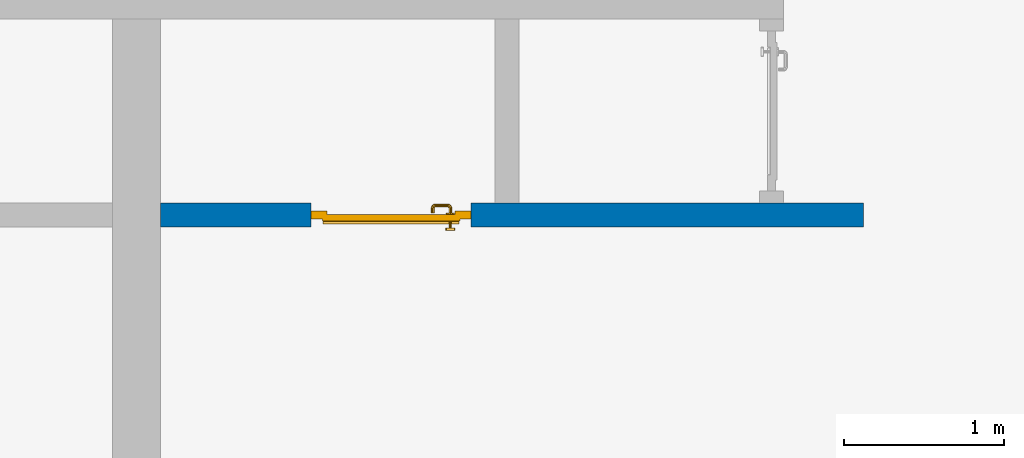
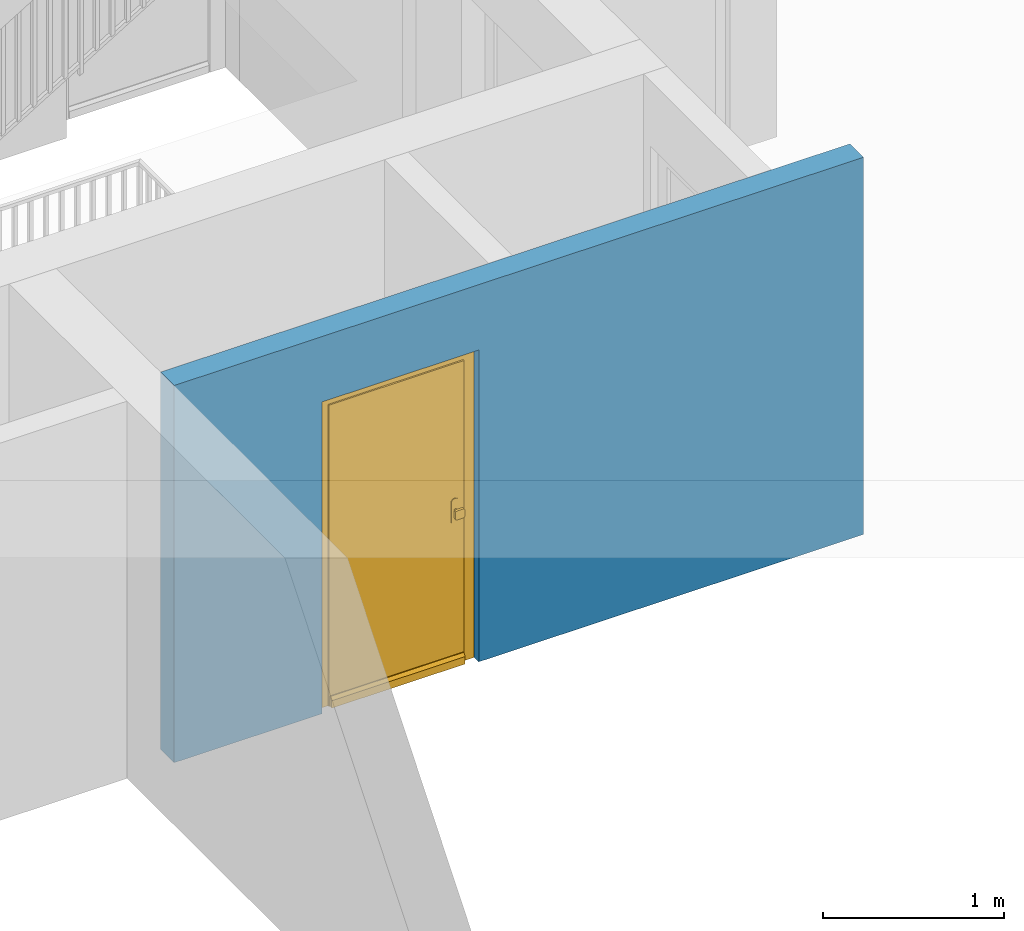
# One storey, part 3 of 48: 1 door, 1 wall, 1 opening.
"""IFC4 building model written with IfcOpenShell, lengths in metres."""

import ifcopenshell
import ifcopenshell.guid

model = None  # the IFC model being written
_history = None  # IfcOwnerHistory: only IFC2X3 demands one
_inside = {}  # id of a spatial element -> (the spatial element, [elements in it])
_under = {}  # id of a project, library or spatial element -> (it, [spatial elements below it])
_declared = {}  # id of a project -> (the project, [libraries it declares])
_typed = {}  # id of a type object -> (the type object, [elements of that type])
_made_of = {}  # id of a material, layer set ... -> (it, [elements and type objects made of it])


def new_model(schema):
    """Start an empty IFC model of exactly this schema.

    Asked for "IFC4X3", IfcOpenShell would pick the latest addendum, in which some entities
    have other attributes; the version numbers below select the first issue.
    IFC2X3 requires an IfcOwnerHistory on every rooted entity: one is made here for all.
    """
    global model, _history
    if schema == "IFC4X3":
        model = ifcopenshell.file(schema_version=(4, 3, 0, 0))
    else:
        model = ifcopenshell.file(schema=schema)
    _inside.clear()
    _under.clear()
    _declared.clear()
    _typed.clear()
    _made_of.clear()
    _history = None
    if model.schema == "IFC2X3":
        org = make("IfcOrganization", Name="unknown")
        user = make(
            "IfcPersonAndOrganization",
            ThePerson=make("IfcPerson", FamilyName="unknown"),
            TheOrganization=org,
        )
        app = make(
            "IfcApplication",
            ApplicationDeveloper=org,
            Version="unknown",
            ApplicationFullName="unknown",
            ApplicationIdentifier="unknown",
        )
        _history = make(
            "IfcOwnerHistory",
            OwningUser=user,
            OwningApplication=app,
            ChangeAction="ADDED",
            CreationDate=0,
        )
    return model


def make(cls, **values):
    """One entity of the class cls with the attributes given. An attribute that is None is left unset."""
    return model.create_entity(
        cls, **{name: value for name, value in values.items() if value is not None}
    )


def entity(cls, *values):
    """Any entity or typed value of the class cls, its attributes in the order of the schema. None: left unset."""
    e = model.create_entity(cls)
    for i, value in enumerate(values):
        if value is not None:
            e[i] = value
    return e


def rooted(cls, **values):
    """An entity with a GlobalId (a new one), such as an element, a storey or a relation."""
    return make(cls, GlobalId=ifcopenshell.guid.new(), OwnerHistory=_history, **values)


def si_unit(unit_type, name, prefix=None):
    """IfcSIUnit, for example si_unit("LENGTHUNIT", "METRE", prefix="MILLI")."""
    return make("IfcSIUnit", UnitType=unit_type, Prefix=prefix, Name=name)


def converted_unit(unit_type, name, factor, base, dimensions=None, offset=None):
    """IfcConversionBasedUnit, such as the inch: factor (a typed value) times the base unit."""
    return make(
        "IfcConversionBasedUnit"
        if offset is None
        else "IfcConversionBasedUnitWithOffset",
        ConversionOffset=offset,
        Dimensions=None
        if dimensions is None
        else entity("IfcDimensionalExponents", *dimensions),
        UnitType=unit_type,
        Name=name,
        ConversionFactor=make(
            "IfcMeasureWithUnit", ValueComponent=factor, UnitComponent=base
        ),
    )


def derived_unit(unit_type, elements):
    """IfcDerivedUnit: a product of units, each with its exponent."""
    return make(
        "IfcDerivedUnit",
        Elements=[
            make("IfcDerivedUnitElement", Unit=unit, Exponent=power)
            for unit, power in elements
        ],
        UnitType=unit_type,
    )


def assignment(units):
    """IfcUnitAssignment: the units of a project."""
    return None if units is None else make("IfcUnitAssignment", Units=units)


def point(xyz):
    """IfcCartesianPoint."""
    return None if xyz is None else make("IfcCartesianPoint", Coordinates=xyz)


def direction(xyz):
    """IfcDirection."""
    return None if xyz is None else make("IfcDirection", DirectionRatios=xyz)


def frame(location, z_axis=None, x_axis=None):
    """IfcAxis2Placement3D, a coordinate frame: its origin and axes. An axis left out is left unset."""
    return make(
        "IfcAxis2Placement3D",
        Location=point(location),
        Axis=direction(z_axis),
        RefDirection=direction(x_axis),
    )


def origin_with_axes():
    """The frame at (0, 0, 0) with the z axis (0, 0, 1) and the x axis (1, 0, 0) written out."""
    return frame((0.0, 0.0, 0.0), z_axis=(0.0, 0.0, 1.0), x_axis=(1.0, 0.0, 0.0))


def place(relative_to, where):
    """IfcLocalPlacement: puts the frame where relative to a parent placement (None: the world)."""
    return make(
        "IfcLocalPlacement", PlacementRelTo=relative_to, RelativePlacement=where
    )


def context(
    kind, dimensions, precision=None, world=None, true_north=None, identifier=None
):
    """IfcGeometricRepresentationContext, for example the 3D "Model" context."""
    return make(
        "IfcGeometricRepresentationContext",
        ContextIdentifier=identifier,
        ContextType=kind,
        CoordinateSpaceDimension=dimensions,
        Precision=precision,
        WorldCoordinateSystem=world,
        TrueNorth=true_north,
    )


def subcontext(parent, identifier, kind, view, scale=None):
    """IfcGeometricRepresentationSubContext, for example "Body" below "Model"."""
    return make(
        "IfcGeometricRepresentationSubContext",
        ContextIdentifier=identifier,
        ContextType=kind,
        ParentContext=parent,
        TargetScale=scale,
        TargetView=view,
    )


def project(units=None, contexts=None):
    """IfcProject with its units and contexts."""
    return rooted(
        "IfcProject",
        Name="project",
        RepresentationContexts=contexts,
        UnitsInContext=assignment(units),
    )


def spatial(cls, under=None, at=None, **own):
    """A site, building, storey or space (cls), placed at a placement, below another one or the project."""
    s = rooted(cls, ObjectPlacement=at, **own)
    if under is not None:
        _under.setdefault(under.id(), (under, []))[1].append(s)
    return s


def point_list(points):
    """IfcCartesianPointList2D or 3D."""
    cls = (
        "IfcCartesianPointList2D" if len(points[0]) == 2 else "IfcCartesianPointList3D"
    )
    return make(cls, CoordList=points)


def polygons(points, faces, closed=None, point_numbers=None):
    """IfcPolygonalFaceSet: a face is its outer loop, then its inner loops; points numbered from 1."""
    made = []
    for loops in faces:
        if len(loops) == 1:
            made.append(make("IfcIndexedPolygonalFace", CoordIndex=loops[0]))
        else:
            made.append(
                make(
                    "IfcIndexedPolygonalFaceWithVoids",
                    CoordIndex=loops[0],
                    InnerCoordIndices=loops[1:],
                )
            )
    return make(
        "IfcPolygonalFaceSet",
        Coordinates=point_list(points),
        Closed=closed,
        Faces=made,
        PnIndex=point_numbers,
    )


def shape(context_of_items, identifier, shape_type, items):
    """IfcShapeRepresentation: the items that make up one representation, for example the "Body"."""
    return make(
        "IfcShapeRepresentation",
        ContextOfItems=context_of_items,
        RepresentationIdentifier=identifier,
        RepresentationType=shape_type,
        Items=items,
    )


def source(mapping_origin, context_of_items, identifier, shape_type, items):
    """IfcRepresentationMap: a shape defined once, which mapped items show again and again."""
    return make(
        "IfcRepresentationMap",
        MappingOrigin=mapping_origin,
        MappedRepresentation=shape(context_of_items, identifier, shape_type, items),
    )


def transform(
    local_origin,
    x_axis=None,
    y_axis=None,
    z_axis=None,
    scale=None,
    scale2=None,
    scale3=None,
    uniform=True,
):
    """IfcCartesianTransformationOperator3D, or its non-uniform kind. x_axis, y_axis, z_axis: its Axis1, 2, 3."""
    if uniform:
        return make(
            "IfcCartesianTransformationOperator3D",
            Axis1=direction(x_axis),
            Axis2=direction(y_axis),
            LocalOrigin=point(local_origin),
            Scale=scale,
            Axis3=direction(z_axis),
        )
    return make(
        "IfcCartesianTransformationOperator3DnonUniform",
        Axis1=direction(x_axis),
        Axis2=direction(y_axis),
        LocalOrigin=point(local_origin),
        Scale=scale,
        Axis3=direction(z_axis),
        Scale2=scale2,
        Scale3=scale3,
    )


def mapped(mapping_source, mapping_target):
    """IfcMappedItem: shows the shape of a source again, moved by a transform."""
    return make(
        "IfcMappedItem", MappingSource=mapping_source, MappingTarget=mapping_target
    )


def material(Name=None, Category=None):
    """IfcMaterial."""
    return make("IfcMaterial", Name=Name, Category=Category)


def made_of(thing, what):
    """Note that an element or type object is made of a material, layer set ...; save() writes the relation."""
    if what is not None:
        _made_of.setdefault(what.id(), (what, []))[1].append(thing)
    return thing


def type_object(cls, material=None, **own):
    """A type object (cls), such as IfcWallType, which elements share."""
    return made_of(rooted(cls, **own), material)


def element(
    cls,
    number,
    at=None,
    inside=None,
    cuts=None,
    type_object=None,
    material=None,
    context=None,
    identifier="Body",
    shape_type=None,
    held_by="IfcProductDefinitionShape",
    body=None,
    shapes=None,
    **own,
):
    """One element of the class cls, such as IfcWall. Its Tag is "e" and its number.

    at: its placement. inside: the storey or other place that contains it. cuts: it is an
    opening in that element (IfcRelVoidsElement). A single representation is given by context,
    identifier, shape_type and body (its items); several are given by shapes. held_by: the class
    of the entity that holds the representations. save() writes the other relations.
    """
    e = rooted(cls, Tag="e%d" % number, ObjectPlacement=at, **own)
    if body is not None:
        shapes = [shape(context, identifier, shape_type, body)]
    if shapes is not None:
        e.Representation = make(held_by, Representations=shapes)
    if inside is not None:
        _inside.setdefault(inside.id(), (inside, []))[1].append(e)
    if cuts is not None:
        rooted(
            "IfcRelVoidsElement", RelatingBuildingElement=cuts, RelatedOpeningElement=e
        )
    if type_object is not None:
        _typed.setdefault(type_object.id(), (type_object, []))[1].append(e)
    return made_of(e, material)


def fill(opening, filler):
    """IfcRelFillsElement: the door or window that sits in an opening."""
    return rooted(
        "IfcRelFillsElement",
        RelatingOpeningElement=opening,
        RelatedBuildingElement=filler,
    )


def aggregate(whole, parts):
    """IfcRelAggregates: a whole, such as a stair, and the parts it consists of."""
    return rooted("IfcRelAggregates", RelatingObject=whole, RelatedObjects=parts)


def save(model, path):
    """Write the relations noted so far, then the file.

    IfcRelAggregates (storeys below a building ...), IfcRelContainedInSpatialStructure (elements
    in a storey), IfcRelDefinesByType, IfcRelAssociatesMaterial and IfcRelDeclares: one each for
    every whole, place, type object, material and project.
    """
    for whole, parts in _under.values():
        aggregate(whole, parts)
    for where, things in _inside.values():
        rooted(
            "IfcRelContainedInSpatialStructure",
            RelatedElements=things,
            RelatingStructure=where,
        )
    for kind, things in _typed.values():
        rooted("IfcRelDefinesByType", RelatedObjects=things, RelatingType=kind)
    for what, things in _made_of.values():
        rooted("IfcRelAssociatesMaterial", RelatedObjects=things, RelatingMaterial=what)
    for by, libraries in _declared.values():
        rooted("IfcRelDeclares", RelatingContext=by, RelatedDefinitions=libraries)
    model.write(path)


model = new_model("IFC4")

# Units and contexts
model_context = context("Model", 3, precision=1e-05, world=origin_with_axes(), true_north=direction((0.0, 1.0)))
body_context = subcontext(model_context, "Body", "Model", "MODEL_VIEW")
ifc_project = project(units=[si_unit("LENGTHUNIT", "METRE"), si_unit("AREAUNIT", "SQUARE_METRE"), si_unit("VOLUMEUNIT", "CUBIC_METRE"), converted_unit("PLANEANGLEUNIT", "DEGREE", entity("IfcPlaneAngleMeasure", 0.0174532925199), si_unit("PLANEANGLEUNIT", "RADIAN"), dimensions=[0, 0, 0, 0, 0, 0, 0]), converted_unit("TIMEUNIT", "Year", entity("IfcTimeMeasure", 31556926.0), si_unit("TIMEUNIT", "SECOND"), dimensions=[0, 0, 1, 0, 0, 0, 0]), si_unit("MASSUNIT", "GRAM", prefix="KILO"), si_unit("THERMODYNAMICTEMPERATUREUNIT", "DEGREE_CELSIUS"), si_unit("LUMINOUSINTENSITYUNIT", "LUMEN"), si_unit("ENERGYUNIT", "JOULE", prefix="MEGA"), derived_unit("THERMALCONDUCTANCEUNIT", [(si_unit("POWERUNIT", "WATT"), 1), (si_unit("LENGTHUNIT", "METRE"), -1), (si_unit("THERMODYNAMICTEMPERATUREUNIT", "KELVIN"), -1)]), derived_unit("SPECIFICHEATCAPACITYUNIT", [(si_unit("ENERGYUNIT", "JOULE"), 1), (si_unit("MASSUNIT", "GRAM", prefix="KILO"), -1), (si_unit("THERMODYNAMICTEMPERATUREUNIT", "KELVIN"), -1)]), derived_unit("MASSDENSITYUNIT", [(si_unit("MASSUNIT", "GRAM", prefix="KILO"), 1), (si_unit("VOLUMEUNIT", "CUBIC_METRE"), -1)])], contexts=[model_context])

# Site, building, storey
site_placement = place(None, origin_with_axes())
site = spatial("IfcSite", under=ifc_project, at=site_placement, CompositionType="ELEMENT")
building_placement = place(site_placement, origin_with_axes())
building = spatial("IfcBuilding", under=site, at=building_placement, CompositionType="ELEMENT")
storey_placement = place(building_placement, frame((0.0, 0.0, 3.4), z_axis=(0.0, 0.0, 1.0), x_axis=(1.0, 0.0, 0.0)))
storey = spatial("IfcBuildingStorey", under=building, at=storey_placement, Name="1. Geschoss", CompositionType="ELEMENT", Elevation=3.4)

# Wall, opening, door
ifc_material = material()
wall_type = type_object("IfcWallType", Name="150", PredefinedType="NOTDEFINED")
wall_placement = place(storey_placement, frame((-1.2021993804, -4.12881223104, 0.0), z_axis=(0.0, 0.0, 1.0), x_axis=(1.0, 0.0, 0.0)))
wall = element("IfcWall", 1, at=wall_placement, inside=storey, type_object=wall_type, material=ifc_material, Name="Wand-002", PredefinedType="NOTDEFINED", context=body_context, shape_type="Tessellation", body=[
    polygons([(1.09, 0.15, 2.1), (1.09, 0.15, 0.0), (0.15, 0.15, 0.0), (0.15, 0.15, 2.54), (4.54, 0.15, 2.54), (4.54, 0.15, 0.0), (2.09, 0.15, 0.0), (2.09, 0.15, 2.1), (1.09, 0.05, 0.0), (1.09, 0.0, 2.1), (1.09, 0.0, 0.0), (0.15, 0.0, 0.0), (0.15, 0.0, 2.54), (4.54, 0.0, 2.54), (4.54, 0.0, 0.0), (2.09, 0.05, 0.0), (2.09, 0.0, 0.0), (2.09, 0.0, 2.1)], [[[1, 2, 3, 4, 5, 6, 7, 8]], [[9, 2, 1, 10, 11]], [[2, 9, 11, 12, 3]], [[4, 3, 12, 13]], [[5, 4, 13, 14]], [[14, 15, 6, 5]], [[16, 7, 6, 15, 17]], [[8, 7, 16, 17, 18]], [[1, 8, 18, 10]], [[12, 11, 10, 18, 17, 15, 14, 13]]], closed=True),
])
opening_placement = place(wall_placement, frame((1.59, 0.0, 0.0), z_axis=(0.0, 0.0, 1.0), x_axis=(1.0, 0.0, 0.0)))
opening = element("IfcOpeningElement", 2, at=opening_placement, cuts=wall, context=body_context, identifier="Reference", shape_type="Tessellation", body=[
    polygons([(0.5, 0.05, 0.0), (0.5, 0.05, 2.1), (0.5, -0.001, 2.1), (0.5, -0.001, 0.0), (0.5, 0.151, 0.0), (0.5, 0.151, 2.1), (-0.5, 0.05, 2.1), (-0.5, -0.001, 2.1), (-0.5, 0.151, 2.1), (-0.5, -0.001, 0.0), (-0.5, 0.05, 0.0), (-0.5, 0.151, 0.0)], [[[1, 2, 3, 4]], [[2, 1, 5, 6]], [[7, 8, 3, 2, 6, 9]], [[8, 10, 4, 3]], [[1, 4, 10, 11, 12, 5]], [[6, 5, 12, 9]], [[7, 11, 10, 8]], [[11, 7, 9, 12]]], closed=True),
])
door_type = type_object("IfcDoorType", Name="Eingang 01 1-Fl 26", OperationType="SINGLE_SWING_RIGHT", PredefinedType="DOOR")
shared_shape = source(origin_with_axes(), body_context, "Body", "Tessellation", [
    polygons([(0.5, -0.05, 0.0), (0.5, -0.03, 0.0), (0.5, -0.03, 2.1), (0.5, -0.05, 2.1), (0.4, -0.05, 0.0), (0.4, -0.03, 0.0), (0.4, -0.03, 2.0), (0.1301, -0.03, 2.0), (0.0001, -0.03, 2.0), (-0.4, -0.03, 2.0), (-0.4, -0.03, 0.0), (-0.5, -0.03, 0.0), (-0.5, -0.03, 2.1), (-0.5, -0.05, 2.1), (-0.5, -0.05, 0.0), (-0.4, -0.05, 0.0), (-0.4, -0.05, 2.0), (0.0001, -0.05, 2.0), (0.1301, -0.05, 2.0), (0.4, -0.05, 2.0)], [[[1, 2, 3, 4]], [[5, 6, 2, 1]], [[2, 6, 7, 8, 9, 10, 11, 12, 13, 3]], [[4, 3, 13, 14]], [[1, 4, 14, 15, 16, 17, 18, 19, 20, 5]], [[20, 7, 6, 5]], [[19, 8, 7, 20]], [[18, 9, 8, 19]], [[17, 10, 9, 18]], [[16, 11, 10, 17]], [[15, 12, 11, 16]], [[14, 13, 12, 15]]], closed=True),
    polygons([(0.5, -0.03, 0.0), (0.5, 0.0, 0.0), (0.5, 0.0, 2.1), (0.5, -0.03, 2.1), (0.43, -0.03, 0.0), (0.43, 0.0, 0.0), (0.43, 0.0, 2.03), (0.1001, 0.0, 2.03), (0.0301, 0.0, 2.03), (-0.43, 0.0, 2.03), (-0.43, 0.0, 0.0), (-0.5, 0.0, 0.0), (-0.5, 0.0, 2.1), (-0.5, -0.03, 2.1), (-0.5, -0.03, 0.0), (-0.43, -0.03, 0.0), (-0.43, -0.03, 2.03), (0.0301, -0.03, 2.03), (0.1001, -0.03, 2.03), (0.43, -0.03, 2.03)], [[[1, 2, 3, 4]], [[5, 6, 2, 1]], [[2, 6, 7, 8, 9, 10, 11, 12, 13, 3]], [[4, 3, 13, 14]], [[1, 4, 14, 15, 16, 17, 18, 19, 20, 5]], [[20, 7, 6, 5]], [[19, 8, 7, 20]], [[18, 9, 8, 19]], [[17, 10, 9, 18]], [[16, 11, 10, 17]], [[15, 12, 11, 16]], [[14, 13, 12, 15]]], closed=True),
    polygons([(0.43, 0.01, 0.0), (-0.43, 0.01, 0.0), (-0.43, 0.01, 2.03), (0.43, 0.01, 2.03), (0.43, -0.03, 0.0), (-0.43, -0.03, 0.0), (-0.43, -0.03, 2.03), (0.43, -0.03, 2.03)], [[[1, 2, 3, 4]], [[2, 1, 5, 6]], [[3, 2, 6, 7]], [[4, 3, 7, 8]], [[1, 4, 8, 5]], [[6, 5, 8, 7]]], closed=True),
    polygons([(0.425, 0.03, 0.0), (-0.425, 0.03, 0.0), (-0.425, 0.03, 0.05), (0.425, 0.03, 0.05), (0.425, 0.01, 0.0), (-0.425, 0.01, 0.0), (-0.425, 0.01, 0.07), (-0.425, 0.015, 0.07), (0.425, 0.015, 0.07), (0.425, 0.01, 0.07)], [[[1, 2, 3, 4]], [[5, 6, 2, 1]], [[2, 6, 7, 8, 3]], [[4, 3, 8, 9]], [[1, 4, 9, 10, 5]], [[10, 7, 6, 5]], [[9, 8, 7, 10]]], closed=True),
    polygons([(-0.3835, -0.04, 1.0733826859), (-0.37, -0.04, 1.077), (-0.37, -0.0399, 1.077), (-0.3835, -0.0399, 1.0733826859), (-0.393382685902, -0.04, 1.0635), (-0.397, -0.04, 1.05), (-0.393382685902, -0.04, 1.0365), (-0.3835, -0.04, 1.0266173141), (-0.37, -0.04, 1.023), (-0.3565, -0.04, 1.0266173141), (-0.346617314098, -0.04, 1.0365), (-0.343, -0.04, 1.05), (-0.346617314098, -0.04, 1.0635), (-0.3565, -0.04, 1.0733826859), (-0.3565, -0.0399, 1.0733826859), (-0.37, -0.0301, 1.077), (-0.3835, -0.0301, 1.0733826859), (-0.393382685902, -0.0399, 1.0635), (-0.397, -0.0399, 1.05), (-0.393382685902, -0.0399, 1.0365), (-0.3835, -0.0399, 1.0266173141), (-0.37, -0.0399, 1.023), (-0.3565, -0.0399, 1.0266173141), (-0.346617314098, -0.0399, 1.0365), (-0.343, -0.0399, 1.05), (-0.346617314098, -0.0399, 1.0635), (-0.3565, -0.0301, 1.0733826859), (-0.37, -0.03, 1.077), (-0.3835, -0.03, 1.0733826859), (-0.393382685902, -0.0301, 1.0635), (-0.397, -0.0301, 1.05), (-0.393382685902, -0.0301, 1.0365), (-0.3835, -0.0301, 1.0266173141), (-0.37, -0.0301, 1.023), (-0.3565, -0.0301, 1.0266173141), (-0.346617314098, -0.0301, 1.0365), (-0.343, -0.0301, 1.05), (-0.346617314098, -0.0301, 1.0635), (-0.3565, -0.03, 1.0733826859), (-0.346617314098, -0.03, 1.0635), (-0.343, -0.03, 1.05), (-0.346617314098, -0.03, 1.0365), (-0.3565, -0.03, 1.0266173141), (-0.37, -0.03, 1.023), (-0.3835, -0.03, 1.0266173141), (-0.393382685902, -0.03, 1.0365), (-0.397, -0.03, 1.05), (-0.393382685902, -0.03, 1.0635)], [[[1, 2, 3, 4]], [[2, 1, 5, 6, 7, 8, 9, 10, 11, 12, 13, 14]], [[2, 14, 15, 3]], [[4, 3, 16, 17]], [[5, 1, 4, 18]], [[6, 5, 18, 19]], [[7, 6, 19, 20]], [[8, 7, 20, 21]], [[9, 8, 21, 22]], [[10, 9, 22, 23]], [[11, 10, 23, 24]], [[12, 11, 24, 25]], [[13, 12, 25, 26]], [[14, 13, 26, 15]], [[3, 15, 27, 16]], [[17, 16, 28, 29]], [[18, 4, 17, 30]], [[19, 18, 30, 31]], [[20, 19, 31, 32]], [[21, 20, 32, 33]], [[22, 21, 33, 34]], [[23, 22, 34, 35]], [[24, 23, 35, 36]], [[25, 24, 36, 37]], [[26, 25, 37, 38]], [[15, 26, 38, 27]], [[16, 27, 39, 28]], [[28, 39, 40, 41, 42, 43, 44, 45, 46, 47, 48, 29]], [[30, 17, 29, 48]], [[31, 30, 48, 47]], [[32, 31, 47, 46]], [[33, 32, 46, 45]], [[34, 33, 45, 44]], [[35, 34, 44, 43]], [[36, 35, 43, 42]], [[37, 36, 42, 41]], [[38, 37, 41, 40]], [[27, 38, 40, 39]]], closed=True),
    polygons([(-0.362532169224, -0.04, 0.959692280177), (-0.365, -0.04, 0.9544), (-0.365, -0.04, 0.952886751346), (-0.346703916638, -0.04, 0.96345), (-0.35655, -0.04, 0.973296083362), (-0.363279754556, -0.04, 0.961639806549), (-0.362532169224, -0.039, 0.959692280177), (-0.365, -0.039, 0.9544), (-0.365, -0.039, 0.952886751346), (-0.365, -0.039, 0.95), (-0.365, -0.039, 0.947113248654), (-0.365, -0.039, 0.941339745962), (-0.365, -0.039, 0.9375), (-0.365, -0.04, 0.9375), (-0.365, -0.04, 0.941339745962), (-0.365, -0.04, 0.947113248654), (-0.365, -0.04, 0.95), (-0.3431, -0.04, 0.95), (-0.346617314098, -0.04, 0.9635), (-0.3565, -0.04, 0.973382685902), (-0.364624817685, -0.04, 0.965143815798), (-0.37, -0.04, 0.9769), (-0.37, -0.04, 0.967425445323), (-0.364624817685, -0.039, 0.965143815798), (-0.363279754556, -0.039, 0.961639806549), (-0.35705, -0.039, 0.972430057958), (-0.347569942042, -0.039, 0.96295), (-0.3441, -0.039, 0.95), (-0.347569942042, -0.039, 0.93705), (-0.35705, -0.039, 0.927569942042), (-0.37, -0.039, 0.9241), (-0.37, -0.039, 0.9325), (-0.366464466094, -0.039, 0.933964466094), (-0.366464466094, -0.04, 0.933964466094), (-0.35655, -0.04, 0.926703916638), (-0.37, -0.04, 0.9325), (-0.37, -0.04, 0.9231), (-0.346703916638, -0.04, 0.93655), (-0.343, -0.04, 0.95), (-0.346617314098, -0.0399, 0.9635), (-0.3565, -0.0399, 0.973382685902), (-0.37, -0.04, 0.977), (-0.375375182315, -0.04, 0.965143815798), (-0.38345, -0.04, 0.973296083362), (-0.376720245444, -0.04, 0.961639806549), (-0.37, -0.039, 0.967425445323), (-0.37, -0.039, 0.9759), (-0.357, -0.039, 0.972516660498), (-0.347483339502, -0.039, 0.963), (-0.344, -0.039, 0.95), (-0.347483339502, -0.039, 0.937), (-0.357, -0.039, 0.927483339502), (-0.38295, -0.039, 0.927569942042), (-0.375, -0.039, 0.941339745962), (-0.375, -0.039, 0.9375), (-0.373535533906, -0.039, 0.933964466094), (-0.37, -0.039, 0.924), (-0.373535533906, -0.04, 0.933964466094), (-0.375, -0.04, 0.9375), (-0.375, -0.04, 0.941339745962), (-0.38345, -0.04, 0.926703916638), (-0.37, -0.04, 0.923), (-0.3565, -0.04, 0.926617314098), (-0.346617314098, -0.04, 0.9365), (-0.343, -0.0399, 0.95), (-0.346617314098, -0.0301, 0.9635), (-0.3565, -0.0301, 0.973382685902), (-0.37, -0.0399, 0.977), (-0.3835, -0.04, 0.973382685902), (-0.375375182315, -0.039, 0.965143815798), (-0.377467830776, -0.04, 0.959692280177), (-0.393296083362, -0.04, 0.96345), (-0.375, -0.04, 0.952886751346), (-0.375, -0.04, 0.9544), (-0.377467830776, -0.039, 0.959692280177), (-0.376720245444, -0.039, 0.961639806549), (-0.38295, -0.039, 0.972430057958), (-0.37, -0.039, 0.976), (-0.357, -0.0389, 0.972516660498), (-0.347483339502, -0.0389, 0.963), (-0.344, -0.0389, 0.95), (-0.347483339502, -0.0389, 0.937), (-0.357, -0.0389, 0.927483339502), (-0.392430057958, -0.039, 0.93705), (-0.375, -0.039, 0.947113248654), (-0.375, -0.039, 0.9544), (-0.375, -0.04, 0.95), (-0.375, -0.04, 0.947113248654), (-0.375, -0.039, 0.95), (-0.375, -0.039, 0.952886751346), (-0.383, -0.039, 0.927483339502), (-0.37, -0.0389, 0.924), (-0.393296083362, -0.04, 0.93655), (-0.3835, -0.04, 0.926617314098), (-0.37, -0.0399, 0.923), (-0.3565, -0.0399, 0.926617314098), (-0.346617314098, -0.0399, 0.9365), (-0.343, -0.0301, 0.95), (-0.346617314098, -0.03, 0.9635), (-0.3565, -0.03, 0.973382685902), (-0.37, -0.0301, 0.977), (-0.3835, -0.0399, 0.973382685902), (-0.393382685902, -0.04, 0.9635), (-0.3969, -0.04, 0.95), (-0.392430057958, -0.039, 0.96295), (-0.383, -0.039, 0.972516660498), (-0.37, -0.0389, 0.976), (-0.357, -0.0301, 0.972516660498), (-0.347483339502, -0.0301, 0.963), (-0.344, -0.0301, 0.95), (-0.347483339502, -0.0301, 0.937), (-0.357, -0.0301, 0.927483339502), (-0.392516660498, -0.039, 0.937), (-0.3959, -0.039, 0.95), (-0.383, -0.0389, 0.927483339502), (-0.37, -0.0301, 0.924), (-0.393382685902, -0.04, 0.9365), (-0.3835, -0.0399, 0.926617314098), (-0.37, -0.0301, 0.923), (-0.3565, -0.0301, 0.926617314098), (-0.346617314098, -0.0301, 0.9365), (-0.343, -0.03, 0.95), (-0.346703916638, -0.03, 0.96345), (-0.35655, -0.03, 0.973296083362), (-0.37, -0.03, 0.977), (-0.3835, -0.0301, 0.973382685902), (-0.393382685902, -0.0399, 0.9635), (-0.397, -0.04, 0.95), (-0.392516660498, -0.039, 0.963), (-0.383, -0.0389, 0.972516660498), (-0.37, -0.0301, 0.976), (-0.357, -0.03, 0.972516660498), (-0.347483339502, -0.03, 0.963), (-0.344, -0.03, 0.95), (-0.347483339502, -0.03, 0.937), (-0.357, -0.03, 0.927483339502), (-0.392516660498, -0.0389, 0.937), (-0.396, -0.039, 0.95), (-0.383, -0.0301, 0.927483339502), (-0.37, -0.03, 0.924), (-0.393382685902, -0.0399, 0.9365), (-0.3835, -0.0301, 0.926617314098), (-0.37, -0.03, 0.923), (-0.3565, -0.03, 0.926617314098), (-0.346617314098, -0.03, 0.9365), (-0.3431, -0.03, 0.95), (-0.347396736961, -0.03, 0.96305), (-0.35695, -0.03, 0.972603263039), (-0.37, -0.03, 0.9769), (-0.3835, -0.03, 0.973382685902), (-0.393382685902, -0.0301, 0.9635), (-0.397, -0.0399, 0.95), (-0.392516660498, -0.0389, 0.963), (-0.383, -0.0301, 0.972516660498), (-0.37, -0.03, 0.976), (-0.3439, -0.03, 0.95), (-0.347396736961, -0.03, 0.93695), (-0.35695, -0.03, 0.927396736961), (-0.392516660498, -0.0301, 0.937), (-0.396, -0.0389, 0.95), (-0.383, -0.03, 0.927483339502), (-0.37, -0.03, 0.9239), (-0.393382685902, -0.0301, 0.9365), (-0.3835, -0.03, 0.926617314098), (-0.37, -0.03, 0.9231), (-0.35655, -0.03, 0.926703916638), (-0.346703916638, -0.03, 0.93655), (-0.37, -0.03, 0.9761), (-0.38345, -0.03, 0.973296083362), (-0.393382685902, -0.03, 0.9635), (-0.397, -0.0301, 0.95), (-0.392516660498, -0.0301, 0.963), (-0.383, -0.03, 0.972516660498), (-0.392516660498, -0.03, 0.937), (-0.396, -0.0301, 0.95), (-0.38305, -0.03, 0.927396736961), (-0.393382685902, -0.03, 0.9365), (-0.38345, -0.03, 0.926703916638), (-0.38305, -0.03, 0.972603263039), (-0.393296083362, -0.03, 0.96345), (-0.397, -0.03, 0.95), (-0.392516660498, -0.03, 0.963), (-0.392603263039, -0.03, 0.93695), (-0.396, -0.03, 0.95), (-0.393296083362, -0.03, 0.93655), (-0.392603263039, -0.03, 0.96305), (-0.3969, -0.03, 0.95), (-0.3961, -0.03, 0.95)], [[[1, 2, 3, 4, 5, 6]], [[2, 1, 7, 8]], [[2, 8, 9, 10, 11, 12, 13, 14, 15, 16, 17, 3]], [[17, 18, 4, 3]], [[19, 20, 5, 4]], [[21, 6, 5, 22, 23]], [[1, 6, 21, 24, 25, 7]], [[7, 25, 26, 27, 9, 8]], [[9, 27, 28, 10]], [[10, 28, 29, 11]], [[11, 29, 30, 12]], [[31, 32, 33, 13, 12, 30]], [[14, 13, 33, 34]], [[35, 15, 14, 34, 36, 37]], [[15, 35, 38, 16]], [[16, 38, 18, 17]], [[39, 19, 4, 18]], [[40, 41, 20, 19]], [[20, 42, 22, 5]], [[43, 23, 22, 44, 45]], [[21, 23, 46, 24]], [[24, 46, 47, 26, 25]], [[27, 26, 48, 49]], [[28, 27, 49, 50]], [[29, 28, 50, 51]], [[30, 29, 51, 52]], [[53, 54, 55, 56, 32, 31]], [[34, 33, 32, 36]], [[31, 30, 52, 57]], [[37, 36, 58, 59, 60, 61]], [[62, 63, 35, 37]], [[63, 64, 38, 35]], [[64, 39, 18, 38]], [[65, 40, 19, 39]], [[66, 67, 41, 40]], [[41, 68, 42, 20]], [[42, 69, 44, 22]], [[23, 43, 70, 46]], [[71, 45, 44, 72, 73, 74]], [[43, 45, 71, 75, 76, 70]], [[70, 76, 77, 47, 46]], [[26, 47, 78, 48]], [[49, 48, 79, 80]], [[50, 49, 80, 81]], [[51, 50, 81, 82]], [[52, 51, 82, 83]], [[54, 53, 84, 85]], [[86, 74, 73, 87, 88, 60, 59, 55, 54, 85, 89, 90]], [[58, 56, 55, 59]], [[36, 32, 56, 58]], [[53, 31, 57, 91]], [[57, 52, 83, 92]], [[88, 93, 61, 60]], [[94, 62, 37, 61]], [[95, 96, 63, 62]], [[96, 97, 64, 63]], [[97, 65, 39, 64]], [[98, 66, 40, 65]], [[99, 100, 67, 66]], [[67, 101, 68, 41]], [[68, 102, 69, 42]], [[69, 103, 72, 44]], [[73, 72, 104, 87]], [[71, 74, 86, 75]], [[75, 86, 90, 105, 77, 76]], [[47, 77, 106, 78]], [[48, 78, 107, 79]], [[80, 79, 108, 109]], [[81, 80, 109, 110]], [[82, 81, 110, 111]], [[83, 82, 111, 112]], [[84, 53, 91, 113]], [[85, 84, 114, 89]], [[87, 104, 93, 88]], [[89, 114, 105, 90]], [[91, 57, 92, 115]], [[92, 83, 112, 116]], [[117, 94, 61, 93]], [[118, 95, 62, 94]], [[119, 120, 96, 95]], [[120, 121, 97, 96]], [[121, 98, 65, 97]], [[122, 99, 66, 98]], [[123, 124, 100, 99]], [[100, 125, 101, 67]], [[101, 126, 102, 68]], [[102, 127, 103, 69]], [[103, 128, 104, 72]], [[77, 105, 129, 106]], [[78, 106, 130, 107]], [[79, 107, 131, 108]], [[109, 108, 132, 133]], [[110, 109, 133, 134]], [[111, 110, 134, 135]], [[112, 111, 135, 136]], [[113, 91, 115, 137]], [[114, 84, 113, 138]], [[128, 117, 93, 104]], [[105, 114, 138, 129]], [[115, 92, 116, 139]], [[116, 112, 136, 140]], [[141, 118, 94, 117]], [[142, 119, 95, 118]], [[143, 144, 120, 119]], [[144, 145, 121, 120]], [[145, 122, 98, 121]], [[146, 123, 99, 122]], [[147, 148, 124, 123]], [[124, 149, 125, 100]], [[125, 150, 126, 101]], [[126, 151, 127, 102]], [[127, 152, 128, 103]], [[106, 129, 153, 130]], [[107, 130, 154, 131]], [[108, 131, 155, 132]], [[133, 132, 148, 147]], [[134, 133, 147, 156]], [[135, 134, 156, 157]], [[136, 135, 157, 158]], [[137, 115, 139, 159]], [[138, 113, 137, 160]], [[152, 141, 117, 128]], [[129, 138, 160, 153]], [[139, 116, 140, 161]], [[140, 136, 158, 162]], [[163, 142, 118, 141]], [[164, 143, 119, 142]], [[165, 166, 144, 143]], [[166, 167, 145, 144]], [[167, 146, 122, 145]], [[156, 147, 123, 146]], [[148, 168, 149, 124]], [[149, 169, 150, 125]], [[150, 170, 151, 126]], [[151, 171, 152, 127]], [[130, 153, 172, 154]], [[131, 154, 173, 155]], [[132, 155, 168, 148]], [[157, 156, 146, 167]], [[158, 157, 167, 166]], [[159, 139, 161, 174]], [[160, 137, 159, 175]], [[171, 163, 141, 152]], [[153, 160, 175, 172]], [[161, 140, 162, 176]], [[162, 158, 166, 165]], [[177, 164, 142, 163]], [[178, 165, 143, 164]], [[168, 179, 169, 149]], [[169, 180, 170, 150]], [[170, 181, 171, 151]], [[154, 172, 182, 173]], [[155, 173, 179, 168]], [[174, 161, 176, 183]], [[175, 159, 174, 184]], [[181, 177, 163, 171]], [[172, 175, 184, 182]], [[176, 162, 165, 178]], [[185, 178, 164, 177]], [[179, 186, 180, 169]], [[180, 187, 181, 170]], [[173, 182, 186, 179]], [[183, 176, 178, 185]], [[184, 174, 183, 188]], [[187, 185, 177, 181]], [[182, 184, 188, 186]], [[186, 188, 187, 180]], [[188, 183, 185, 187]]], closed=True),
    polygons([(-0.38, -0.04, 1.05), (-0.377071067812, -0.04, 1.04292893219), (-0.377071067812, -0.070696439392, 1.04292893219), (-0.38, -0.0709849140336, 1.05), (-0.37, -0.04, 1.04), (-0.37, -0.07, 1.04), (-0.375518993221, -0.0784992452783, 1.04292893219), (-0.378277987014, -0.0796420579258, 1.05), (-0.377071067812, -0.04, 1.05707106781), (-0.377071067812, -0.070696439392, 1.05707106781), (-0.362928932188, -0.04, 1.04292893219), (-0.362928932188, -0.069303560608, 1.04292893219), (-0.368858192988, -0.0757402514855, 1.04), (-0.370704557509, -0.0857045575088, 1.04292893219), (-0.372816199938, -0.0878161999379, 1.05), (-0.375518993221, -0.0784992452783, 1.05707106781), (-0.37, -0.04, 1.06), (-0.37, -0.07, 1.06), (-0.36, -0.04, 1.05), (-0.36, -0.0690150859664, 1.05), (-0.362197392755, -0.0729812576926, 1.04292893219), (-0.365606601718, -0.0806066017178, 1.04), (-0.363499245278, -0.0905189932208, 1.04292893219), (-0.364642057926, -0.0932779870137, 1.05), (-0.370704557509, -0.0857045575088, 1.05707106781), (-0.368858192988, -0.0757402514855, 1.06), (-0.362928932188, -0.04, 1.05707106781), (-0.362928932188, -0.069303560608, 1.05707106781), (-0.359438398962, -0.0718384450452, 1.05), (-0.360508645927, -0.0755086459268, 1.04292893219), (-0.360740251485, -0.0838581929877, 1.04), (-0.355696439392, -0.0920710678119, 1.04292893219), (-0.355984914034, -0.095, 1.05), (-0.363499245278, -0.0905189932208, 1.05707106781), (-0.365606601718, -0.0806066017178, 1.06), (-0.362197392755, -0.0729812576926, 1.05707106781), (-0.358397003498, -0.0733970034977, 1.05), (-0.357981257693, -0.0771973927545, 1.04292893219), (-0.355, -0.085, 1.04), (-0.274303560608, -0.0920710678119, 1.04292893219), (-0.274015085966, -0.095, 1.05), (-0.355696439392, -0.0920710678119, 1.05707106781), (-0.360740251485, -0.0838581929877, 1.06), (-0.360508645927, -0.0755086459268, 1.05707106781), (-0.356838445045, -0.0744383989617, 1.05), (-0.354303560608, -0.0779289321881, 1.04292893219), (-0.275, -0.085, 1.04), (-0.266500754722, -0.0905189932208, 1.04292893219), (-0.265357942074, -0.0932779870137, 1.05), (-0.274303560608, -0.0920710678119, 1.05707106781), (-0.355, -0.085, 1.06), (-0.357981257693, -0.0771973927545, 1.05707106781), (-0.354015085966, -0.075, 1.05), (-0.275696439392, -0.0779289321881, 1.04292893219), (-0.269259748515, -0.0838581929877, 1.04), (-0.259295442491, -0.0857045575088, 1.04292893219), (-0.257183800062, -0.0878161999379, 1.05), (-0.266500754722, -0.0905189932208, 1.05707106781), (-0.275, -0.085, 1.06), (-0.354303560608, -0.0779289321881, 1.05707106781), (-0.275984914034, -0.075, 1.05), (-0.272018742307, -0.0771973927545, 1.04292893219), (-0.264393398282, -0.0806066017178, 1.04), (-0.254481006779, -0.0784992452783, 1.04292893219), (-0.251722012986, -0.0796420579258, 1.05), (-0.259295442491, -0.0857045575088, 1.05707106781), (-0.269259748515, -0.0838581929877, 1.06), (-0.275696439392, -0.0779289321881, 1.05707106781), (-0.273161554955, -0.0744383989617, 1.05), (-0.269491354073, -0.0755086459268, 1.04292893219), (-0.261141807012, -0.0757402514855, 1.04), (-0.252928932188, -0.070696439392, 1.04292893219), (-0.25, -0.0709849140336, 1.05), (-0.254481006779, -0.0784992452783, 1.05707106781), (-0.264393398282, -0.0806066017178, 1.06), (-0.272018742307, -0.0771973927545, 1.05707106781), (-0.271602996502, -0.0733970034977, 1.05), (-0.267802607245, -0.0729812576926, 1.04292893219), (-0.26, -0.07, 1.04), (-0.252928932188, -0.04, 1.04292893219), (-0.25, -0.04, 1.05), (-0.252928932188, -0.070696439392, 1.05707106781), (-0.261141807012, -0.0757402514855, 1.06), (-0.269491354073, -0.0755086459268, 1.05707106781), (-0.270561601038, -0.0718384450452, 1.05), (-0.267071067812, -0.069303560608, 1.04292893219), (-0.26, -0.04, 1.04), (-0.267071067812, -0.04, 1.04292893219), (-0.27, -0.04, 1.05), (-0.267071067812, -0.04, 1.05707106781), (-0.26, -0.04, 1.06), (-0.252928932188, -0.04, 1.05707106781), (-0.26, -0.07, 1.06), (-0.267802607245, -0.0729812576926, 1.05707106781), (-0.27, -0.0690150859664, 1.05), (-0.267071067812, -0.069303560608, 1.05707106781)], [[[1, 2, 3, 4]], [[2, 5, 6, 3]], [[4, 3, 7, 8]], [[9, 1, 4, 10]], [[5, 11, 12, 6]], [[3, 6, 13, 7]], [[8, 7, 14, 15]], [[10, 4, 8, 16]], [[17, 9, 10, 18]], [[11, 19, 20, 12]], [[6, 12, 21, 13]], [[7, 13, 22, 14]], [[15, 14, 23, 24]], [[16, 8, 15, 25]], [[18, 10, 16, 26]], [[27, 17, 18, 28]], [[19, 27, 28, 20]], [[12, 20, 29, 21]], [[13, 21, 30, 22]], [[14, 22, 31, 23]], [[24, 23, 32, 33]], [[25, 15, 24, 34]], [[26, 16, 25, 35]], [[28, 18, 26, 36]], [[20, 28, 36, 29]], [[21, 29, 37, 30]], [[22, 30, 38, 31]], [[23, 31, 39, 32]], [[33, 32, 40, 41]], [[34, 24, 33, 42]], [[35, 25, 34, 43]], [[36, 26, 35, 44]], [[29, 36, 44, 37]], [[30, 37, 45, 38]], [[31, 38, 46, 39]], [[32, 39, 47, 40]], [[41, 40, 48, 49]], [[42, 33, 41, 50]], [[43, 34, 42, 51]], [[44, 35, 43, 52]], [[37, 44, 52, 45]], [[38, 45, 53, 46]], [[39, 46, 54, 47]], [[40, 47, 55, 48]], [[49, 48, 56, 57]], [[50, 41, 49, 58]], [[51, 42, 50, 59]], [[52, 43, 51, 60]], [[45, 52, 60, 53]], [[46, 53, 61, 54]], [[47, 54, 62, 55]], [[48, 55, 63, 56]], [[57, 56, 64, 65]], [[58, 49, 57, 66]], [[59, 50, 58, 67]], [[60, 51, 59, 68]], [[53, 60, 68, 61]], [[54, 61, 69, 62]], [[55, 62, 70, 63]], [[56, 63, 71, 64]], [[65, 64, 72, 73]], [[66, 57, 65, 74]], [[67, 58, 66, 75]], [[68, 59, 67, 76]], [[61, 68, 76, 69]], [[62, 69, 77, 70]], [[63, 70, 78, 71]], [[64, 71, 79, 72]], [[73, 72, 80, 81]], [[74, 65, 73, 82]], [[75, 66, 74, 83]], [[76, 67, 75, 84]], [[69, 76, 84, 77]], [[70, 77, 85, 78]], [[71, 78, 86, 79]], [[72, 79, 87, 80]], [[81, 80, 87, 88, 89, 90, 91, 92]], [[82, 73, 81, 92]], [[83, 74, 82, 93]], [[84, 75, 83, 94]], [[77, 84, 94, 85]], [[78, 85, 95, 86]], [[79, 86, 88, 87]], [[86, 95, 89, 88]], [[95, 96, 90, 89]], [[96, 93, 91, 90]], [[93, 82, 92, 91]], [[94, 83, 93, 96]], [[85, 94, 96, 95]]], closed=False),
    polygons([(-0.364696699141, 0.015, 1.04469669914), (-0.3625, 0.015, 1.05), (-0.364696699141, 0.015, 1.05530330086), (-0.37, 0.015, 1.0575), (-0.375303300859, 0.015, 1.05530330086), (-0.3775, 0.015, 1.05), (-0.375303300859, 0.015, 1.04469669914), (-0.37, 0.015, 1.0425), (-0.364696699141, 0.055, 1.04469669914), (-0.3625, 0.055, 1.05), (-0.364696699141, 0.055, 1.05530330086), (-0.37, 0.055, 1.0575), (-0.375303300859, 0.055, 1.05530330086), (-0.3775, 0.055, 1.05), (-0.375303300859, 0.055, 1.04469669914), (-0.37, 0.055, 1.0425)], [[[1, 2, 3, 4, 5, 6, 7, 8]], [[1, 9, 10, 2]], [[2, 10, 11, 3]], [[3, 11, 12, 4]], [[4, 12, 13, 5]], [[5, 13, 14, 6]], [[6, 14, 15, 7]], [[7, 15, 16, 8]], [[8, 16, 9, 1]], [[9, 16, 15, 14, 13, 12, 11, 10]]], closed=True),
    polygons([(-0.395, 0.01, 0.975), (-0.395, 0.015, 0.975), (-0.393096988313, 0.015, 0.965432914191), (-0.393096988313, 0.01, 0.965432914191), (-0.395, 0.01, 1.1), (-0.395, 0.015, 1.1), (-0.393096988313, 0.015, 1.10956708581), (-0.38767766953, 0.015, 1.11767766953), (-0.379567085809, 0.015, 1.12309698831), (-0.37, 0.015, 1.125), (-0.360432914191, 0.015, 1.12309698831), (-0.35232233047, 0.015, 1.11767766953), (-0.346903011687, 0.015, 1.10956708581), (-0.345, 0.015, 1.1), (-0.345, 0.015, 0.975), (-0.346903011687, 0.015, 0.965432914191), (-0.35232233047, 0.015, 0.95732233047), (-0.360432914191, 0.015, 0.951903011687), (-0.37, 0.015, 0.95), (-0.379567085809, 0.015, 0.951903011687), (-0.38767766953, 0.015, 0.95732233047), (-0.38767766953, 0.01, 0.95732233047), (-0.379567085809, 0.01, 0.951903011687), (-0.37, 0.01, 0.95), (-0.360432914191, 0.01, 0.951903011687), (-0.35232233047, 0.01, 0.95732233047), (-0.346903011687, 0.01, 0.965432914191), (-0.345, 0.01, 0.975), (-0.345, 0.01, 1.1), (-0.346903011687, 0.01, 1.10956708581), (-0.35232233047, 0.01, 1.11767766953), (-0.360432914191, 0.01, 1.12309698831), (-0.37, 0.01, 1.125), (-0.379567085809, 0.01, 1.12309698831), (-0.38767766953, 0.01, 1.11767766953), (-0.393096988313, 0.01, 1.10956708581)], [[[1, 2, 3, 4]], [[5, 6, 2, 1]], [[2, 6, 7, 8, 9, 10, 11, 12, 13, 14, 15, 16, 17, 18, 19, 20, 21, 3]], [[4, 3, 21, 22]], [[1, 4, 22, 23, 24, 25, 26, 27, 28, 29, 30, 31, 32, 33, 34, 35, 36, 5]], [[36, 7, 6, 5]], [[35, 8, 7, 36]], [[34, 9, 8, 35]], [[33, 10, 9, 34]], [[32, 11, 10, 33]], [[31, 12, 11, 32]], [[30, 13, 12, 31]], [[29, 14, 13, 30]], [[28, 15, 14, 29]], [[27, 16, 15, 28]], [[26, 17, 16, 27]], [[25, 18, 17, 26]], [[24, 19, 18, 25]], [[23, 20, 19, 24]], [[22, 21, 20, 23]]], closed=True),
    polygons([(-0.39, 0.055, 1.08), (-0.39, 0.07, 1.08), (-0.395, 0.07, 1.07866025404), (-0.395, 0.055, 1.07866025404), (-0.35, 0.055, 1.08), (-0.35, 0.07, 1.08), (-0.345, 0.07, 1.07866025404), (-0.341339745962, 0.07, 1.075), (-0.34, 0.07, 1.07), (-0.34, 0.07, 1.03), (-0.341339745962, 0.07, 1.025), (-0.345, 0.07, 1.02133974596), (-0.35, 0.07, 1.02), (-0.39, 0.07, 1.02), (-0.395, 0.07, 1.02133974596), (-0.398660254038, 0.07, 1.025), (-0.4, 0.07, 1.03), (-0.4, 0.07, 1.07), (-0.398660254038, 0.07, 1.075), (-0.398660254038, 0.055, 1.075), (-0.4, 0.055, 1.07), (-0.4, 0.055, 1.03), (-0.398660254038, 0.055, 1.025), (-0.395, 0.055, 1.02133974596), (-0.39, 0.055, 1.02), (-0.35, 0.055, 1.02), (-0.345, 0.055, 1.02133974596), (-0.341339745962, 0.055, 1.025), (-0.34, 0.055, 1.03), (-0.34, 0.055, 1.07), (-0.341339745962, 0.055, 1.075), (-0.345, 0.055, 1.07866025404)], [[[1, 2, 3, 4]], [[5, 6, 2, 1]], [[2, 6, 7, 8, 9, 10, 11, 12, 13, 14, 15, 16, 17, 18, 19, 3]], [[4, 3, 19, 20]], [[1, 4, 20, 21, 22, 23, 24, 25, 26, 27, 28, 29, 30, 31, 32, 5]], [[32, 7, 6, 5]], [[31, 8, 7, 32]], [[30, 9, 8, 31]], [[29, 10, 9, 30]], [[28, 11, 10, 29]], [[27, 12, 11, 28]], [[26, 13, 12, 27]], [[25, 14, 13, 26]], [[24, 15, 14, 25]], [[23, 16, 15, 24]], [[22, 17, 16, 23]], [[21, 18, 17, 22]], [[20, 19, 18, 21]]], closed=True),
])
door_placement = place(opening_placement, frame((0.4, 0.0, 0.0), z_axis=(0.0, 0.0, 1.0), x_axis=(-1.0, 0.0, 0.0)))
door = element("IfcDoor", 3, at=door_placement, inside=storey, type_object=door_type, OverallHeight=2.1, OverallWidth=1.0, PredefinedType="DOOR", context=body_context, shape_type="MappedRepresentation", body=[
    mapped(shared_shape, transform((0.4, -0.05, 0.0))),
])
fill(opening, door)

save(model, "model.ifc")
